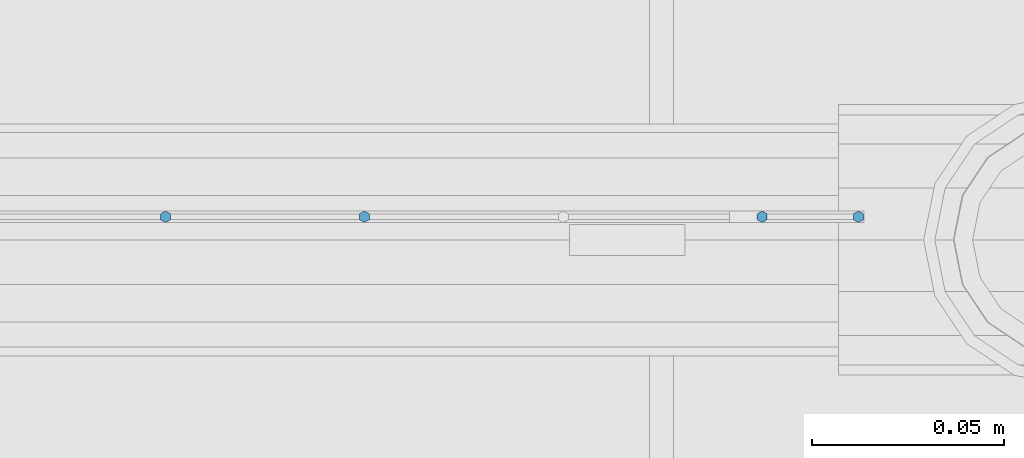
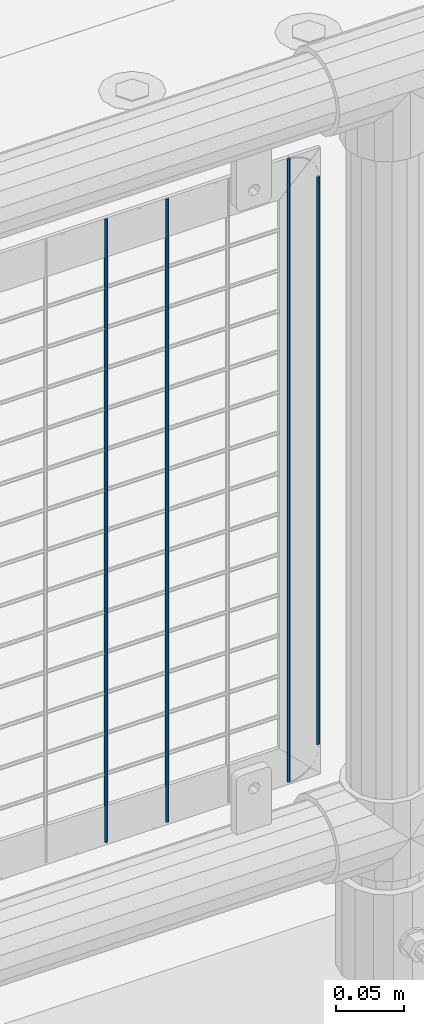
# One storey, part 69 of 193: 4 columns.
"""IFC2X3 building model written with IfcOpenShell, lengths in millimetres."""

from ifc_helpers import new_model, si_unit, frame, origin_with_axes, place, context, subcontext, project, spatial, faceted_brep, material, type_object, element, save


model = new_model("IFC2X3")

# Units and contexts
model_context = context("Model", 3, precision=1e-05, world=origin_with_axes())
body_context = subcontext(model_context, "Body", "Model", "MODEL_VIEW")
ifc_project = project(units=[si_unit("LENGTHUNIT", "METRE", prefix="MILLI"), si_unit("AREAUNIT", "SQUARE_METRE"), si_unit("VOLUMEUNIT", "CUBIC_METRE"), si_unit("MASSUNIT", "GRAM", prefix="KILO"), si_unit("TIMEUNIT", "SECOND"), si_unit("PLANEANGLEUNIT", "RADIAN"), si_unit("SOLIDANGLEUNIT", "STERADIAN"), si_unit("THERMODYNAMICTEMPERATUREUNIT", "DEGREE_CELSIUS"), si_unit("LUMINOUSINTENSITYUNIT", "LUMEN")], contexts=[model_context])

# Site, building, storey
site_placement = place(None, origin_with_axes())
site = spatial("IfcSite", under=ifc_project, at=site_placement, CompositionType="ELEMENT")
building_placement = place(site_placement, origin_with_axes())
building = spatial("IfcBuilding", under=site, at=building_placement, Name="Standard", CompositionType="ELEMENT")
storey_placement = place(building_placement, origin_with_axes())
storey = spatial("IfcBuildingStorey", under=building, at=storey_placement, Name="Undefined", CompositionType="ELEMENT", Elevation=0.0)

# Columns
ifc_material = material(Name="Misc_Undefined")
column_type = type_object("IfcColumnType", Name="D3", PredefinedType="NOTDEFINED")
for number, where, z_axis, x_axis in (
    (1, (-35380.315, 28670.5, 353.02), (-1.0, 0.0, 0.0), (0.0, 0.0, 1.0)),
    (2, (-35431.97, 28670.5, 353.02), (-1.0, 0.0, 0.0), (0.0, 0.0, 1.0)),
    (3, (-35277.005, 28670.5, 353.02), (-1.0, 0.0, 0.0), (0.0, 0.0, 1.0)),
):
    element("IfcColumn", number, at=place(storey_placement, frame(where, z_axis=z_axis, x_axis=x_axis)), inside=storey, type_object=column_type, material=ifc_material, ObjectType="D3", context=body_context, shape_type="Brep", body=[
        faceted_brep([(0.0, -1.49999999999636, 3.63797880709171e-12), (0.0, -0.75, -1.29903810567669), (560.0, -0.75, -1.29903810567703), (560.0, -1.5, 0.0), (0.0, 0.75, -1.29903810567669), (560.0, 0.75, -1.29903810567703), (0.0, 1.50000000000364, 7.27595761418343e-12), (560.0, 1.5, 0.0), (0.0, 0.75, 1.29903810567669), (560.0, 0.75, 1.29903810567703), (0.0, -0.75, 1.29903810567669), (560.0, -0.75, 1.29903810567703)], [[[0, 1, 2, 3]], [[1, 4, 5, 2]], [[4, 6, 7, 5]], [[6, 8, 9, 7]], [[8, 10, 11, 9]], [[10, 0, 3, 11]], [[5, 7, 9, 11, 3, 2]], [[10, 8, 6, 4, 1, 0]]]),
    ])
column_placement = place(storey_placement, frame((-35252.0, 28670.5, 378.02), z_axis=(-1.0, 0.0, 0.0), x_axis=(0.0, 0.0, 1.0)))
element("IfcColumn", 4, at=column_placement, inside=storey, type_object=column_type, material=ifc_material, ObjectType="D3", context=body_context, shape_type="Brep", body=[
    faceted_brep([(0.0, -1.49999999999636, 3.63797880709171e-12), (0.0, -0.75, -1.29903810567669), (510.0, -0.75, -1.29903810567703), (510.0, -1.5, 0.0), (0.0, 0.75, -1.29903810567669), (510.0, 0.75, -1.29903810567703), (0.0, 1.50000000000364, 7.27595761418343e-12), (510.0, 1.5, 0.0), (0.0, 0.75, 1.29903810567669), (510.0, 0.75, 1.29903810567703), (0.0, -0.75, 1.29903810567669), (510.0, -0.75, 1.29903810567703)], [[[0, 1, 2, 3]], [[1, 4, 5, 2]], [[4, 6, 7, 5]], [[6, 8, 9, 7]], [[8, 10, 11, 9]], [[10, 0, 3, 11]], [[5, 7, 9, 11, 3, 2]], [[10, 8, 6, 4, 1, 0]]]),
])

save(model, "model.ifc")
